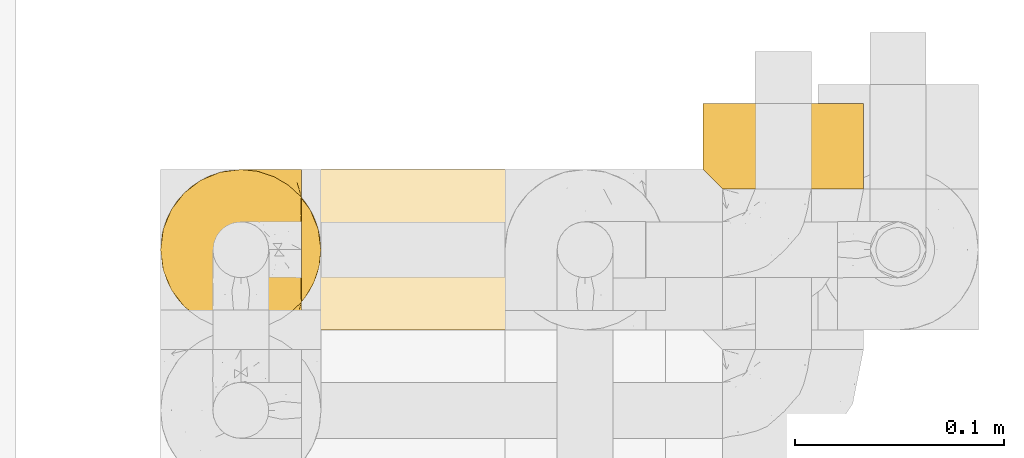
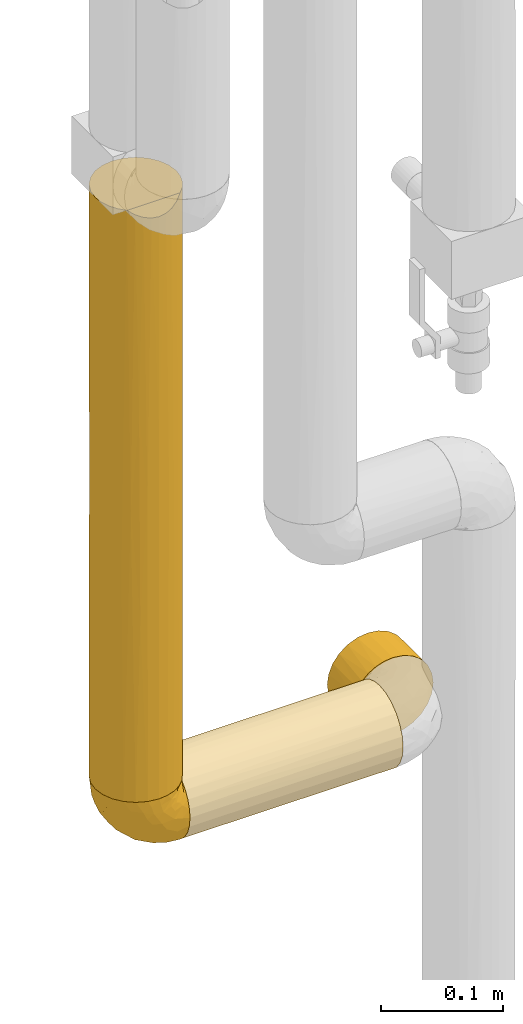
# One storey, part 287 of 827: 4 coverings.
"""IFC2X3 building model written with IfcOpenShell, lengths in millimetres."""

from ifc_helpers import new_model, entity, si_unit, converted_unit, derived_unit, direction, frame, origin, place, context, subcontext, project, spatial, faceted_brep, element, save


model = new_model("IFC2X3")

# Units and contexts
model_context = context("Model", 3, precision=0.01, world=origin(), true_north=direction((6.12303176911189e-17, 1.0)))
body_context = subcontext(model_context, "Body", "Model", "MODEL_VIEW")
ifc_project = project(units=[si_unit("LENGTHUNIT", "METRE", prefix="MILLI"), si_unit("AREAUNIT", "SQUARE_METRE"), si_unit("VOLUMEUNIT", "CUBIC_METRE"), converted_unit("PLANEANGLEUNIT", "DEGREE", entity("IfcRatioMeasure", 0.0174532925199433), si_unit("PLANEANGLEUNIT", "RADIAN"), dimensions=[0, 0, 0, 0, 0, 0, 0]), si_unit("MASSUNIT", "GRAM", prefix="KILO"), derived_unit("MASSDENSITYUNIT", [(si_unit("MASSUNIT", "GRAM", prefix="KILO"), 1), (si_unit("LENGTHUNIT", "METRE"), -3)]), derived_unit("MOMENTOFINERTIAUNIT", [(si_unit("LENGTHUNIT", "METRE"), 4)]), si_unit("TIMEUNIT", "SECOND"), si_unit("FREQUENCYUNIT", "HERTZ"), si_unit("THERMODYNAMICTEMPERATUREUNIT", "DEGREE_CELSIUS"), derived_unit("THERMALTRANSMITTANCEUNIT", [(si_unit("MASSUNIT", "GRAM", prefix="KILO"), 1), (si_unit("THERMODYNAMICTEMPERATUREUNIT", "KELVIN"), -1), (si_unit("TIMEUNIT", "SECOND"), -3)]), derived_unit("VOLUMETRICFLOWRATEUNIT", [(si_unit("LENGTHUNIT", "METRE"), 3), (si_unit("TIMEUNIT", "SECOND"), -1)]), derived_unit("MASSFLOWRATEUNIT", [(si_unit("MASSUNIT", "GRAM", prefix="KILO"), 1), (si_unit("TIMEUNIT", "SECOND"), -1)]), derived_unit("ROTATIONALFREQUENCYUNIT", [(si_unit("TIMEUNIT", "SECOND"), -1)]), si_unit("ELECTRICCURRENTUNIT", "AMPERE"), si_unit("ELECTRICVOLTAGEUNIT", "VOLT"), si_unit("POWERUNIT", "WATT"), si_unit("FORCEUNIT", "NEWTON", prefix="KILO"), si_unit("ILLUMINANCEUNIT", "LUX"), si_unit("LUMINOUSFLUXUNIT", "LUMEN"), si_unit("LUMINOUSINTENSITYUNIT", "CANDELA"), derived_unit("USERDEFINED", [(si_unit("MASSUNIT", "GRAM", prefix="KILO"), -1), (si_unit("LENGTHUNIT", "METRE"), -2), (si_unit("TIMEUNIT", "SECOND"), 3), (si_unit("LUMINOUSFLUXUNIT", "LUMEN"), 1)]), derived_unit("LINEARVELOCITYUNIT", [(si_unit("LENGTHUNIT", "METRE"), 1), (si_unit("TIMEUNIT", "SECOND"), -1)]), si_unit("PRESSUREUNIT", "PASCAL"), derived_unit("USERDEFINED", [(si_unit("LENGTHUNIT", "METRE"), -2), (si_unit("MASSUNIT", "GRAM", prefix="KILO"), 1), (si_unit("TIMEUNIT", "SECOND"), -2)]), derived_unit("LINEARFORCEUNIT", [(si_unit("MASSUNIT", "GRAM", prefix="KILO"), 1), (si_unit("LENGTHUNIT", "METRE"), 1), (si_unit("TIMEUNIT", "SECOND"), -2), (si_unit("LENGTHUNIT", "METRE"), -1)]), derived_unit("PLANARFORCEUNIT", [(si_unit("MASSUNIT", "GRAM", prefix="KILO"), 1), (si_unit("LENGTHUNIT", "METRE"), 1), (si_unit("TIMEUNIT", "SECOND"), -2), (si_unit("LENGTHUNIT", "METRE"), -2)])], contexts=[model_context])

# Site, building, storey
site_placement = place(None, origin())
site = spatial("IfcSite", under=ifc_project, at=site_placement, CompositionType="ELEMENT")
building_placement = place(site_placement, origin())
building = spatial("IfcBuilding", under=site, at=building_placement, CompositionType="ELEMENT")
storey_placement = place(building_placement, frame((0.0, 0.0, 28200.0)))
storey = spatial("IfcBuildingStorey", under=building, at=storey_placement, Name="08", CompositionType="ELEMENT", Elevation=28200.0)

# Coverings
covering_1_placement = place(storey_placement, frame((34787.85, 15782.05, 1087.5)))
element("IfcCovering", 1, at=covering_1_placement, inside=storey, Name=":ADSK_", ObjectType=":ADSK_", PredefinedType="INSULATION", context=body_context, shape_type="Brep", body=[
    faceted_brep([(74.93, 24.05, 593.5), (77.52, 31.83, 593.5), (78.4, 40.0, 593.5), (77.09, 49.93, 593.5), (73.25, 59.2, 593.5), (67.15, 67.15, 593.5), (59.2, 73.25, 593.5), (49.93, 77.09, 593.5), (40.0, 78.4, 593.5), (30.06, 77.09, 593.5), (20.8, 73.25, 593.5), (12.84, 67.15, 593.5), (6.74, 59.2, 593.5), (2.9, 49.93, 593.5), (1.6, 40.0, 593.5), (2.47, 31.83, 593.5), (5.06, 24.05, 593.5), (9.24, 17.0, 593.5), (14.82, 11.0, 593.5), (65.17, 11.0, 593.5), (70.75, 17.0, 593.5), (69.1, 14.94, 1.6), (63.08, 9.31, 1.6), (56.01, 5.09, 1.6), (48.2, 2.48, 1.6), (40.0, 1.6, 1.6), (30.06, 2.9, 1.6), (20.8, 6.74, 1.6), (12.84, 12.84, 1.6), (6.74, 20.8, 1.6), (2.9, 30.06, 1.6), (1.6, 40.0, 1.6), (2.9, 49.93, 1.6), (6.74, 59.2, 1.6), (12.84, 67.15, 1.6), (20.8, 73.25, 1.6), (30.06, 77.09, 1.6), (40.0, 78.4, 1.6), (48.2, 77.51, 1.6), (56.01, 74.9, 1.6), (63.08, 70.68, 1.6), (69.1, 65.05, 1.6), (2.89, 30.12, 299.72), (29.74, 2.99, 301.9), (33.17, 2.21, 584.71), (26.56, 4.02, 586.52), (6.96, 20.41, 309.24), (1.6, 40.0, 377.12), (11.51, 14.24, 230.02), (17.34, 8.99, 292.9), (40.0, 1.6, 367.72), (1.6, 40.0, 297.55), (20.38, 6.98, 589.48), (23.2, 5.46, 389.92), (24.12, 5.03, 181.9), (40.0, 1.6, 584.1), (50.25, 2.99, 298.79), (59.61, 6.98, 589.48), (53.43, 4.02, 586.52), (56.76, 5.45, 216.93), (62.64, 8.98, 304.65), (46.82, 2.21, 584.71), (71.09, 17.46, 290.54), (74.59, 23.32, 378.86), (73.07, 20.48, 5.57), (76.0, 26.63, 8.5), (77.79, 33.21, 10.29), (77.01, 29.79, 296.29), (78.4, 40.0, 302.2), (78.4, 40.0, 10.9), (78.4, 40.0, 227.27), (74.97, 55.84, 413.2), (77.02, 50.2, 293.21), (74.57, 56.7, 204.39), (71.08, 62.54, 301.5), (73.07, 59.51, 5.57), (77.79, 46.78, 10.29), (76.0, 53.36, 8.5), (65.84, 68.4, 363.94), (59.66, 72.98, 285.81), (40.0, 78.4, 217.97), (49.87, 77.1, 295.47), (40.0, 78.4, 377.12), (32.42, 77.64, 385.18), (25.3, 75.47, 339.18), (2.33, 47.49, 374.62), (4.52, 54.69, 297.55), (16.62, 70.46, 297.55), (9.53, 63.37, 339.18)], [[[0, 1, 2, 3, 4, 5, 6, 7, 8, 9, 10, 11, 12, 13, 14, 15, 16, 17, 18, 19, 20]], [[21, 22, 23, 24, 25, 26, 27, 28, 29, 30, 31, 32, 33, 34, 35, 36, 37, 38, 39, 40, 41]], [[31, 30, 42]], [[43, 44, 45]], [[46, 42, 29]], [[15, 14, 47]], [[29, 48, 46]], [[28, 49, 48]], [[50, 43, 25]], [[42, 47, 51, 31]], [[29, 42, 30]], [[42, 15, 47]], [[17, 16, 46]], [[48, 29, 28]], [[46, 48, 17]], [[16, 15, 42]], [[45, 52, 53]], [[26, 54, 27]], [[45, 53, 43]], [[55, 44, 50]], [[49, 54, 53]], [[50, 44, 43]], [[28, 27, 49]], [[18, 49, 52]], [[48, 18, 17]], [[54, 43, 53]], [[53, 52, 49]], [[43, 26, 25]], [[54, 49, 27]], [[43, 54, 26]], [[48, 49, 18]], [[16, 42, 46]], [[56, 25, 24]], [[57, 58, 59]], [[22, 60, 59]], [[61, 55, 50]], [[25, 56, 50]], [[62, 20, 19]], [[59, 58, 56]], [[19, 57, 60]], [[21, 60, 22]], [[56, 58, 61]], [[63, 1, 0]], [[60, 21, 62]], [[21, 64, 62]], [[64, 65, 63]], [[65, 66, 67]], [[56, 24, 59]], [[1, 68, 2]], [[63, 65, 67]], [[59, 24, 23]], [[63, 20, 62]], [[67, 68, 1]], [[67, 1, 63]], [[63, 62, 64]], [[20, 63, 0]], [[66, 69, 70, 68]], [[66, 68, 67]], [[22, 59, 23]], [[19, 60, 62]], [[59, 60, 57]], [[50, 56, 61]], [[71, 72, 73]], [[5, 4, 74]], [[41, 74, 75]], [[72, 76, 77]], [[78, 41, 40]], [[74, 73, 75]], [[70, 76, 72]], [[6, 78, 79]], [[72, 3, 2]], [[76, 70, 69]], [[77, 75, 73]], [[72, 2, 68, 70]], [[71, 3, 72]], [[78, 74, 41]], [[79, 40, 39]], [[74, 71, 73]], [[80, 81, 38]], [[71, 74, 4]], [[77, 73, 72]], [[8, 7, 81]], [[38, 37, 80]], [[78, 5, 74]], [[6, 81, 7]], [[81, 6, 79]], [[39, 38, 81]], [[78, 6, 5]], [[39, 81, 79]], [[40, 79, 78]], [[3, 71, 4]], [[81, 80, 82, 8]], [[83, 36, 84]], [[32, 85, 86]], [[83, 8, 82, 80, 37]], [[84, 87, 10]], [[87, 84, 35]], [[83, 37, 36]], [[34, 87, 35]], [[87, 11, 10]], [[10, 9, 84]], [[33, 86, 88]], [[85, 51, 47, 14]], [[86, 33, 32]], [[86, 12, 88]], [[34, 88, 87]], [[51, 32, 31]], [[11, 87, 88]], [[33, 88, 34]], [[83, 84, 9]], [[12, 11, 88]], [[86, 85, 13]], [[12, 86, 13]], [[35, 84, 36]], [[51, 85, 32]], [[8, 83, 9]], [[85, 14, 13]], [[52, 45, 44, 55, 61, 58, 57, 19, 18]], [[41, 75, 77, 76, 69, 66, 65, 64, 21]]]),
])
covering_2_placement = place(storey_placement, frame((34855.35, 15782.05, 1020.0)))
element("IfcCovering", 2, at=covering_2_placement, inside=storey, Name=":ADSK_", ObjectType=":ADSK_", PredefinedType="INSULATION", context=body_context, shape_type="Brep", body=[
    faceted_brep([(1.6, 20.8, 6.74), (1.6, 12.84, 12.84), (1.6, 6.74, 20.8), (1.6, 2.9, 30.06), (1.6, 1.6, 40.0), (1.6, 2.48, 48.2), (1.6, 5.09, 56.01), (1.6, 9.31, 63.08), (1.6, 14.94, 69.1), (1.6, 65.05, 69.1), (1.6, 70.68, 63.08), (1.6, 74.9, 56.01), (1.6, 77.51, 48.2), (1.6, 78.4, 40.0), (1.6, 77.09, 30.06), (1.6, 73.25, 20.8), (1.6, 67.15, 12.84), (1.6, 59.2, 6.74), (1.6, 49.93, 2.9), (1.6, 40.0, 1.6), (1.6, 30.06, 2.9), (203.4, 2.9, 30.06), (203.4, 6.74, 20.8), (203.4, 12.84, 12.84), (203.4, 20.8, 6.74), (203.4, 30.06, 2.9), (203.4, 40.0, 1.6), (203.4, 48.2, 2.48), (203.4, 56.01, 5.09), (203.4, 63.08, 9.31), (203.4, 69.1, 14.94), (203.4, 69.1, 65.05), (203.4, 63.08, 70.68), (203.4, 56.01, 74.9), (203.4, 48.2, 77.51), (203.4, 40.0, 78.4), (203.4, 30.06, 77.09), (203.4, 20.8, 73.25), (203.4, 12.84, 67.15), (203.4, 6.74, 59.2), (203.4, 2.9, 49.93), (203.4, 1.6, 40.0), (194.7, 77.79, 33.21), (196.5, 76.0, 26.63), (199.42, 73.07, 20.48), (194.1, 78.4, 40.0), (8.5, 26.63, 76.0), (10.29, 33.21, 77.79), (10.9, 40.0, 78.4), (5.57, 20.48, 73.07), (10.29, 46.78, 77.79), (8.5, 53.36, 76.0), (5.57, 59.51, 73.07), (199.42, 73.07, 59.51), (196.5, 76.0, 53.36), (194.7, 77.79, 46.78)], [[[0, 1, 2, 3, 4, 5, 6, 7, 8, 9, 10, 11, 12, 13, 14, 15, 16, 17, 18, 19, 20]], [[21, 22, 23, 24, 25, 26, 27, 28, 29, 30, 31, 32, 33, 34, 35, 36, 37, 38, 39, 40, 41]], [[42, 43, 14]], [[44, 30, 15]], [[43, 44, 15]], [[45, 42, 13]], [[13, 42, 14]], [[43, 15, 14]], [[30, 16, 15]], [[17, 29, 28]], [[18, 28, 27]], [[19, 27, 26]], [[16, 29, 17]], [[17, 28, 18]], [[27, 19, 18]], [[29, 16, 30]], [[20, 19, 26, 25]], [[0, 20, 25, 24]], [[24, 23, 1, 0]], [[3, 2, 22, 21]], [[4, 3, 21, 41]], [[23, 22, 2, 1]], [[5, 41, 40]], [[6, 40, 39]], [[7, 39, 38]], [[4, 41, 5]], [[5, 40, 6]], [[39, 7, 6]], [[38, 8, 7]], [[46, 37, 36]], [[36, 35, 47]], [[48, 47, 35]], [[49, 8, 37]], [[47, 46, 36]], [[49, 37, 46]], [[37, 8, 38]], [[50, 35, 34]], [[51, 34, 33]], [[52, 33, 32]], [[50, 48, 35]], [[52, 51, 33]], [[9, 52, 32]], [[50, 34, 51]], [[32, 31, 9]], [[31, 53, 10]], [[54, 55, 12]], [[53, 54, 11]], [[10, 53, 11]], [[55, 13, 12]], [[12, 11, 54]], [[13, 55, 45]], [[31, 10, 9]], [[8, 49, 46, 47, 48, 50, 51, 52, 9]], [[55, 54, 53, 31, 30, 44, 43, 42, 45]]]),
])
covering_3_placement = place(storey_placement, frame((34787.8, 15782.0, 1019.95)))
element("IfcCovering", 3, at=covering_3_placement, inside=storey, Name=":ADSK_", ObjectType=":ADSK_", PredefinedType="INSULATION", context=body_context, shape_type="Brep", body=[
    faceted_brep([(69.15, 5.41, 23.36), (69.15, 9.99, 16.07), (69.15, 16.08, 9.98), (69.15, 23.37, 5.4), (69.15, 31.49, 2.56), (69.15, 40.05, 1.6), (69.15, 48.61, 2.56), (69.15, 56.73, 5.41), (69.15, 64.02, 9.99), (69.15, 70.11, 16.08), (69.15, 74.69, 23.37), (69.15, 77.53, 31.49), (69.15, 78.5, 40.05), (69.15, 77.63, 48.15), (69.15, 75.08, 55.88), (69.15, 70.97, 62.9), (69.15, 65.47, 68.89), (69.15, 63.27, 68.89), (69.15, 61.53, 68.89), (69.15, 59.57, 68.89), (69.15, 57.6, 68.89), (69.15, 55.63, 68.89), (69.15, 53.67, 68.89), (69.15, 51.7, 68.89), (69.15, 49.73, 68.89), (69.15, 47.54, 68.89), (69.15, 45.34, 68.89), (69.15, 43.15, 68.89), (69.15, 40.96, 68.89), (69.15, 38.76, 68.89), (69.15, 36.57, 68.89), (69.15, 34.37, 68.89), (69.15, 32.18, 68.89), (69.15, 29.98, 68.89), (69.15, 27.79, 68.89), (69.15, 25.6, 68.89), (69.15, 23.4, 68.89), (69.15, 21.21, 68.89), (69.15, 19.01, 68.89), (69.15, 16.82, 68.89), (69.15, 14.62, 68.89), (69.15, 9.12, 62.89), (69.15, 5.0, 55.86), (69.15, 2.46, 48.13), (69.15, 1.6, 40.05), (69.15, 2.56, 31.49), (68.89, 65.47, 69.15), (62.89, 70.97, 69.15), (55.87, 75.09, 69.15), (48.14, 77.63, 69.15), (40.05, 78.5, 69.15), (30.09, 77.19, 69.15), (20.82, 73.34, 69.15), (12.86, 67.23, 69.15), (6.75, 59.27, 69.15), (2.91, 50.0, 69.15), (1.6, 40.05, 69.15), (2.91, 30.09, 69.15), (6.75, 20.82, 69.15), (12.86, 12.86, 69.15), (20.82, 6.75, 69.15), (30.09, 2.91, 69.15), (40.05, 1.6, 69.15), (48.14, 2.46, 69.15), (55.87, 5.0, 69.15), (62.89, 9.12, 69.15), (68.89, 14.62, 69.15), (68.89, 16.82, 69.15), (68.89, 17.8, 69.15), (68.89, 19.39, 69.15), (68.89, 20.98, 69.15), (68.89, 22.57, 69.15), (68.89, 24.16, 69.15), (68.89, 25.75, 69.15), (68.89, 27.33, 69.15), (68.89, 28.92, 69.15), (68.89, 30.51, 69.15), (68.89, 32.1, 69.15), (68.89, 33.69, 69.15), (68.89, 35.28, 69.15), (68.89, 36.87, 69.15), (68.89, 38.46, 69.15), (68.89, 40.05, 69.15), (68.89, 41.63, 69.15), (68.89, 43.22, 69.15), (68.89, 44.81, 69.15), (68.89, 46.4, 69.15), (68.89, 47.99, 69.15), (68.89, 49.58, 69.15), (68.89, 51.17, 69.15), (68.89, 52.76, 69.15), (68.89, 54.72, 69.15), (68.89, 56.69, 69.15), (68.89, 58.88, 69.15), (68.89, 61.08, 69.15), (68.89, 63.27, 69.15), (68.97, 37.77, 68.96), (68.96, 36.07, 68.97), (68.97, 32.96, 68.97), (68.97, 31.36, 68.97), (68.98, 56.52, 68.95), (68.97, 54.96, 68.96), (68.96, 18.75, 68.98), (68.96, 58.07, 68.97), (68.96, 50.37, 68.97), (68.96, 23.36, 68.98), (68.96, 24.95, 68.97), (68.96, 42.43, 68.97), (69.0, 15.97, 68.94), (68.96, 51.96, 68.98), (68.96, 53.47, 68.98), (68.97, 48.63, 68.96), (68.96, 63.93, 68.97), (68.96, 40.93, 68.98), (68.96, 29.72, 68.98), (68.97, 62.4, 68.97), (68.97, 60.92, 68.96), (68.97, 17.31, 68.97), (68.96, 21.74, 68.97), (68.96, 34.56, 68.98), (68.97, 20.18, 68.96), (68.97, 14.62, 68.97), (69.02, 14.62, 68.94), (69.08, 14.62, 68.92), (68.97, 65.47, 68.97), (68.94, 65.47, 69.02), (68.92, 65.47, 69.08), (68.96, 59.5, 68.98), (68.96, 47.1, 68.97), (68.95, 45.61, 68.98), (68.96, 28.18, 68.97), (68.92, 14.62, 69.08), (68.94, 14.62, 69.02), (68.98, 26.61, 68.96), (69.08, 65.47, 68.92), (69.02, 65.47, 68.94), (68.96, 39.32, 68.97), (68.97, 44.12, 68.96), (61.33, 72.26, 67.02), (53.1, 76.57, 63.33), (63.33, 71.77, 64.61), (49.27, 78.5, 49.27), (55.53, 77.9, 51.4), (54.6, 78.5, 43.94), (41.99, 78.5, 61.87), (57.07, 75.52, 61.54), (57.95, 76.13, 57.95), (51.56, 77.81, 56.12), (41.58, 78.5, 63.4), (61.7, 72.4, 65.41), (63.33, 76.56, 53.1), (65.0, 71.77, 63.04), (67.02, 72.25, 61.33), (61.87, 78.5, 41.99), (43.94, 78.5, 54.6), (61.21, 75.75, 56.6), (63.4, 78.5, 41.58), (33.11, 50.46, 13.72), (52.82, 52.75, 5.82), (43.3, 40.05, 6.74), (33.73, 77.7, 58.82), (36.52, 77.66, 51.58), (24.87, 71.02, 42.09), (14.17, 63.45, 46.12), (18.43, 70.55, 55.56), (28.67, 75.57, 52.38), (26.0, 75.57, 61.54), (49.25, 72.61, 23.76), (59.72, 72.61, 20.5), (55.1, 67.24, 14.64), (44.72, 77.74, 41.77), (34.15, 57.43, 16.28), (5.25, 47.19, 49.4), (6.75, 54.76, 52.34), (55.54, 40.05, 4.3), (10.47, 63.45, 58.67), (25.49, 60.1, 25.26), (35.53, 63.72, 20.17), (48.22, 76.83, 34.7), (58.71, 76.34, 28.67), (57.42, 60.51, 8.62), (34.84, 72.59, 33.37), (36.87, 76.05, 41.35), (45.01, 66.15, 17.15), (44.4, 60.51, 12.68), (23.96, 51.88, 21.47), (11.2, 55.34, 41.11), (10.56, 48.67, 37.53), (16.81, 53.89, 30.64), (17.38, 46.73, 26.66), (21.38, 40.05, 21.38), (32.34, 40.05, 14.06), (4.3, 40.05, 55.54), (20.65, 63.95, 35.17), (29.66, 67.24, 29.04), (39.6, 69.62, 24.34), (42.55, 73.6, 29.33), (6.74, 40.05, 43.3), (14.06, 40.05, 32.34), (26.84, 4.52, 57.75), (5.28, 32.72, 49.41), (18.52, 27.18, 27.85), (33.13, 29.63, 13.7), (55.1, 12.86, 14.63), (57.43, 19.59, 8.61), (20.72, 9.54, 48.85), (11.46, 16.64, 54.13), (17.69, 17.48, 37.84), (49.26, 7.49, 23.75), (59.73, 7.49, 20.49), (58.71, 3.75, 28.66), (29.72, 20.75, 20.83), (35.35, 2.33, 55.15), (43.94, 1.6, 54.6), (41.99, 1.6, 61.87), (63.4, 1.6, 41.58), (4.93, 26.94, 57.58), (17.46, 9.54, 59.91), (10.94, 31.21, 36.94), (8.92, 25.33, 45.72), (52.83, 27.35, 5.82), (29.34, 8.17, 37.91), (30.26, 4.3, 50.18), (44.4, 19.59, 12.67), (39.06, 2.23, 49.29), (43.06, 2.45, 42.64), (54.6, 1.6, 43.94), (49.27, 1.6, 49.27), (42.69, 12.86, 19.45), (48.2, 3.27, 34.7), (61.87, 1.6, 41.99), (33.44, 2.29, 62.29), (29.67, 12.86, 29.01), (38.5, 6.89, 31.47), (23.35, 12.43, 37.18), (34.97, 4.1, 43.45), (53.1, 3.53, 63.33), (59.68, 6.88, 67.23), (62.19, 8.16, 66.07), (64.11, 9.02, 65.22), (57.97, 5.0, 61.99), (57.95, 3.96, 57.95), (63.33, 3.52, 53.09), (51.77, 2.4, 56.84), (67.02, 7.83, 61.33), (64.98, 8.32, 63.06), (55.53, 2.19, 51.41), (61.22, 4.34, 56.61)], [[[0, 1, 2, 3, 4, 5, 6, 7, 8, 9, 10, 11, 12, 13, 14, 15, 16, 17, 18, 19, 20, 21, 22, 23, 24, 25, 26, 27, 28, 29, 30, 31, 32, 33, 34, 35, 36, 37, 38, 39, 40, 41, 42, 43, 44, 45]], [[46, 47, 48, 49, 50, 51, 52, 53, 54, 55, 56, 57, 58, 59, 60, 61, 62, 63, 64, 65, 66, 67, 68, 69, 70, 71, 72, 73, 74, 75, 76, 77, 78, 79, 80, 81, 82, 83, 84, 85, 86, 87, 88, 89, 90, 91, 92, 93, 94, 95]], [[96, 97, 30]], [[98, 77, 99]], [[100, 101, 21]], [[69, 68, 102]], [[20, 19, 103]], [[24, 23, 104]], [[20, 103, 100]], [[72, 105, 106]], [[84, 83, 107]], [[89, 88, 104]], [[108, 67, 66]], [[109, 110, 90]], [[111, 25, 24]], [[112, 17, 16]], [[82, 113, 83]], [[109, 23, 22]], [[114, 76, 75]], [[105, 36, 106]], [[104, 111, 24]], [[18, 115, 116]], [[97, 96, 80]], [[67, 108, 117]], [[105, 71, 118]], [[31, 97, 119]], [[102, 120, 69]], [[108, 121, 122, 123, 40]], [[112, 95, 115]], [[17, 115, 18]], [[94, 116, 115]], [[117, 68, 67]], [[38, 117, 39]], [[112, 124, 125, 126, 46]], [[17, 112, 115]], [[70, 120, 118]], [[39, 117, 108]], [[120, 38, 37]], [[120, 37, 118]], [[120, 70, 69]], [[116, 94, 127]], [[128, 86, 129]], [[117, 38, 102]], [[74, 130, 75]], [[99, 33, 32]], [[115, 95, 94]], [[39, 108, 40]], [[108, 66, 131, 132, 121]], [[105, 72, 71]], [[118, 37, 36]], [[71, 70, 118]], [[35, 106, 36]], [[36, 105, 118]], [[35, 133, 106]], [[74, 73, 133]], [[106, 133, 73]], [[99, 114, 33]], [[133, 35, 34]], [[73, 72, 106]], [[95, 112, 46]], [[112, 16, 134, 135, 124]], [[130, 114, 75]], [[99, 76, 114]], [[114, 130, 33]], [[34, 33, 130]], [[78, 77, 98]], [[98, 119, 78]], [[130, 133, 34]], [[133, 130, 74]], [[79, 97, 80]], [[98, 99, 32]], [[98, 32, 31]], [[77, 76, 99]], [[97, 79, 119]], [[136, 96, 29]], [[30, 97, 31]], [[136, 29, 28]], [[81, 80, 96]], [[29, 96, 30]], [[31, 119, 98]], [[119, 79, 78]], [[96, 136, 81]], [[82, 81, 136]], [[113, 107, 83]], [[84, 107, 137]], [[107, 27, 137]], [[113, 28, 107]], [[27, 107, 28]], [[85, 84, 137]], [[137, 27, 26]], [[113, 136, 28]], [[136, 113, 82]], [[109, 89, 104]], [[86, 85, 129]], [[89, 109, 90]], [[111, 87, 128]], [[26, 129, 137]], [[88, 111, 104]], [[25, 111, 128]], [[22, 110, 109]], [[23, 109, 104]], [[110, 91, 90]], [[100, 92, 101]], [[110, 22, 101]], [[91, 110, 101]], [[116, 19, 18]], [[111, 88, 87]], [[127, 103, 19]], [[25, 128, 26]], [[86, 128, 87]], [[128, 129, 26]], [[137, 129, 85]], [[120, 102, 38]], [[117, 102, 68]], [[91, 101, 92]], [[21, 101, 22]], [[93, 92, 103]], [[100, 21, 20]], [[100, 103, 92]], [[127, 93, 103]], [[93, 127, 94]], [[116, 127, 19]], [[126, 138, 47]], [[48, 138, 139]], [[140, 125, 124]], [[141, 142, 143]], [[144, 49, 139]], [[145, 140, 146]], [[48, 139, 49]], [[139, 145, 147]], [[49, 144, 148, 50]], [[126, 125, 149]], [[14, 13, 150]], [[151, 146, 140]], [[149, 140, 145]], [[152, 151, 135]], [[152, 14, 150]], [[16, 15, 134]], [[13, 153, 150]], [[124, 151, 140]], [[141, 147, 142]], [[14, 152, 15]], [[15, 152, 134]], [[47, 46, 126]], [[139, 154, 144]], [[138, 48, 47]], [[125, 140, 149]], [[135, 134, 152]], [[146, 155, 142]], [[145, 146, 147]], [[149, 139, 138]], [[147, 141, 154]], [[147, 146, 142]], [[139, 147, 154]], [[139, 149, 145]], [[149, 138, 126]], [[155, 146, 151]], [[150, 143, 142]], [[152, 155, 151]], [[150, 142, 155]], [[13, 12, 156, 153]], [[153, 143, 150]], [[152, 150, 155]], [[151, 124, 135]], [[157, 158, 159]], [[160, 154, 161]], [[162, 163, 164]], [[165, 166, 160]], [[167, 168, 169]], [[141, 170, 161]], [[156, 12, 11]], [[158, 157, 171]], [[172, 55, 173]], [[158, 6, 174]], [[175, 54, 53]], [[52, 166, 164]], [[52, 164, 53]], [[54, 175, 173]], [[166, 52, 51]], [[176, 177, 171]], [[178, 143, 179]], [[156, 11, 179]], [[8, 7, 180]], [[169, 9, 8]], [[179, 143, 153, 156]], [[179, 11, 10]], [[168, 179, 10]], [[181, 162, 182]], [[179, 167, 178]], [[183, 184, 177]], [[183, 169, 184]], [[176, 171, 185]], [[172, 186, 187]], [[158, 7, 6]], [[159, 158, 174]], [[184, 180, 158]], [[54, 173, 55]], [[180, 169, 8]], [[188, 189, 187]], [[9, 168, 10]], [[186, 188, 187]], [[190, 157, 159, 191]], [[55, 172, 192]], [[176, 193, 194]], [[161, 170, 182]], [[162, 164, 165]], [[175, 164, 163]], [[51, 50, 148]], [[167, 195, 196]], [[178, 182, 170]], [[6, 5, 174]], [[158, 180, 7]], [[169, 180, 184]], [[169, 168, 9]], [[179, 168, 167]], [[182, 162, 165]], [[162, 194, 193]], [[161, 165, 160]], [[195, 181, 196]], [[192, 172, 197]], [[192, 56, 55]], [[189, 190, 198]], [[198, 197, 187]], [[172, 187, 197]], [[185, 189, 188]], [[198, 187, 189]], [[186, 172, 173]], [[173, 163, 186]], [[193, 186, 163]], [[176, 185, 188]], [[185, 157, 190]], [[188, 186, 193]], [[177, 176, 194]], [[188, 193, 176]], [[162, 193, 163]], [[195, 177, 194]], [[171, 177, 184]], [[181, 195, 194]], [[183, 167, 169]], [[162, 181, 194]], [[196, 182, 178]], [[158, 171, 184]], [[171, 157, 185]], [[177, 195, 183]], [[167, 183, 195]], [[182, 196, 181]], [[178, 170, 143]], [[178, 167, 196]], [[164, 175, 53]], [[173, 175, 163]], [[160, 51, 148]], [[164, 166, 165]], [[51, 160, 166]], [[160, 148, 144, 154]], [[141, 161, 154]], [[182, 165, 161]], [[190, 189, 185]], [[143, 170, 141]], [[60, 199, 61]], [[197, 200, 192]], [[201, 190, 202]], [[200, 57, 192]], [[203, 204, 2]], [[205, 206, 207]], [[208, 209, 210]], [[211, 207, 201]], [[212, 213, 214]], [[45, 215, 210]], [[216, 206, 58]], [[45, 44, 215]], [[59, 217, 60]], [[60, 217, 199]], [[0, 45, 210]], [[218, 201, 219]], [[202, 159, 220]], [[205, 221, 222]], [[223, 204, 203]], [[1, 203, 2]], [[57, 200, 216]], [[220, 3, 204]], [[220, 174, 4]], [[1, 0, 209]], [[212, 224, 213]], [[225, 226, 227]], [[228, 223, 203]], [[208, 210, 229]], [[210, 226, 229]], [[3, 220, 4]], [[58, 206, 59]], [[209, 203, 1]], [[202, 220, 223]], [[228, 203, 208]], [[202, 211, 201]], [[3, 2, 204]], [[202, 190, 191, 159]], [[210, 215, 230, 226]], [[199, 212, 231]], [[232, 233, 221]], [[233, 208, 229]], [[207, 206, 219]], [[217, 206, 205]], [[227, 224, 225]], [[233, 232, 228]], [[201, 207, 219]], [[234, 232, 221]], [[218, 219, 200]], [[202, 223, 211]], [[174, 220, 159]], [[174, 5, 4]], [[61, 231, 62]], [[220, 204, 223]], [[210, 209, 0]], [[203, 209, 208]], [[225, 233, 229]], [[224, 227, 213]], [[221, 233, 235]], [[57, 56, 192]], [[198, 218, 197]], [[200, 219, 216]], [[201, 198, 190]], [[197, 218, 200]], [[198, 201, 218]], [[206, 216, 219]], [[58, 57, 216]], [[231, 212, 214]], [[222, 212, 199]], [[228, 211, 223]], [[207, 211, 232]], [[62, 231, 214]], [[199, 231, 61]], [[233, 228, 208]], [[211, 228, 232]], [[222, 221, 235]], [[234, 205, 207]], [[206, 217, 59]], [[199, 217, 205]], [[205, 222, 199]], [[224, 222, 235]], [[222, 224, 212]], [[224, 235, 225]], [[233, 225, 235]], [[226, 225, 229]], [[205, 234, 221]], [[207, 232, 234]], [[63, 214, 236]], [[214, 213, 236]], [[214, 63, 62]], [[237, 236, 238]], [[238, 132, 131]], [[236, 237, 64]], [[239, 240, 241]], [[63, 236, 64]], [[131, 66, 65]], [[237, 131, 65]], [[242, 230, 43]], [[237, 65, 64]], [[239, 121, 132]], [[42, 242, 43]], [[241, 240, 243]], [[41, 123, 244]], [[43, 230, 215, 44]], [[244, 122, 245]], [[227, 246, 243]], [[241, 243, 246]], [[121, 239, 245]], [[41, 40, 123]], [[132, 238, 239]], [[244, 42, 41]], [[131, 237, 238]], [[240, 239, 238]], [[245, 239, 241]], [[247, 241, 246]], [[247, 244, 245]], [[238, 236, 240]], [[243, 236, 213]], [[236, 243, 240]], [[226, 246, 227]], [[243, 213, 227]], [[226, 242, 246]], [[241, 247, 245]], [[246, 242, 247]], [[244, 247, 242]], [[242, 226, 230]], [[42, 244, 242]], [[122, 244, 123]], [[122, 121, 245]]]),
])
covering_4_placement = place(storey_placement, frame((35047.85, 15849.55, 1020.0)))
element("IfcCovering", 4, at=covering_4_placement, inside=storey, Name=":ADSK_", ObjectType=":ADSK_", PredefinedType="INSULATION", context=body_context, shape_type="Brep", body=[
    faceted_brep([(23.98, 1.6, 5.09), (31.79, 1.6, 2.48), (40.0, 1.6, 1.6), (49.93, 1.6, 2.9), (59.2, 1.6, 6.74), (67.15, 1.6, 12.84), (73.25, 1.6, 20.8), (77.09, 1.6, 30.06), (78.4, 1.6, 40.0), (77.09, 1.6, 49.93), (73.25, 1.6, 59.2), (67.15, 1.6, 67.15), (59.2, 1.6, 73.25), (49.93, 1.6, 77.09), (40.0, 1.6, 78.4), (31.79, 1.6, 77.51), (23.98, 1.6, 74.9), (16.91, 1.6, 70.68), (10.9, 1.6, 65.05), (10.9, 1.6, 14.94), (16.91, 1.6, 9.31), (20.8, 42.5, 6.74), (12.84, 42.5, 12.84), (6.74, 42.5, 20.8), (2.9, 42.5, 30.06), (1.6, 42.5, 40.0), (2.9, 42.5, 49.93), (6.74, 42.5, 59.2), (12.84, 42.5, 67.15), (20.8, 42.5, 73.25), (30.06, 42.5, 77.09), (40.0, 42.5, 78.4), (49.93, 42.5, 77.09), (59.2, 42.5, 73.25), (67.15, 42.5, 67.15), (73.25, 42.5, 59.2), (77.09, 42.5, 49.93), (78.4, 42.5, 40.0), (77.09, 42.5, 30.06), (73.25, 42.5, 20.8), (67.15, 42.5, 12.84), (59.2, 42.5, 6.74), (49.93, 42.5, 2.9), (40.0, 42.5, 1.6), (30.06, 42.5, 2.9), (2.2, 10.29, 33.21), (1.6, 10.9, 40.0), (4.0, 8.5, 26.63), (6.92, 5.57, 20.48), (4.0, 8.5, 53.36), (2.2, 10.29, 46.78), (6.92, 5.57, 59.51)], [[[0, 1, 2, 3, 4, 5, 6, 7, 8, 9, 10, 11, 12, 13, 14, 15, 16, 17, 18, 19, 20]], [[21, 22, 23, 24, 25, 26, 27, 28, 29, 30, 31, 32, 33, 34, 35, 36, 37, 38, 39, 40, 41, 42, 43, 44]], [[45, 46, 25]], [[45, 25, 24]], [[47, 24, 23]], [[47, 45, 24]], [[22, 19, 48]], [[47, 23, 48]], [[48, 23, 22]], [[20, 22, 21]], [[21, 44, 0]], [[43, 1, 44]], [[20, 21, 0]], [[0, 44, 1]], [[43, 2, 1]], [[22, 20, 19]], [[2, 43, 42, 3]], [[3, 42, 41, 4]], [[40, 5, 4, 41]], [[7, 6, 39, 38]], [[8, 7, 38, 37]], [[40, 39, 6, 5]], [[36, 35, 10, 9]], [[37, 36, 9, 8]], [[11, 10, 35, 34]], [[13, 12, 33, 32]], [[14, 13, 32, 31]], [[34, 33, 12, 11]], [[31, 30, 15]], [[29, 28, 17]], [[30, 29, 16]], [[14, 31, 15]], [[17, 16, 29]], [[30, 16, 15]], [[28, 18, 17]], [[49, 27, 26]], [[26, 25, 50]], [[46, 50, 25]], [[18, 28, 51]], [[50, 49, 26]], [[51, 27, 49]], [[51, 28, 27]], [[46, 45, 47, 48, 19, 18, 51, 49, 50]]]),
])

save(model, "model.ifc")
